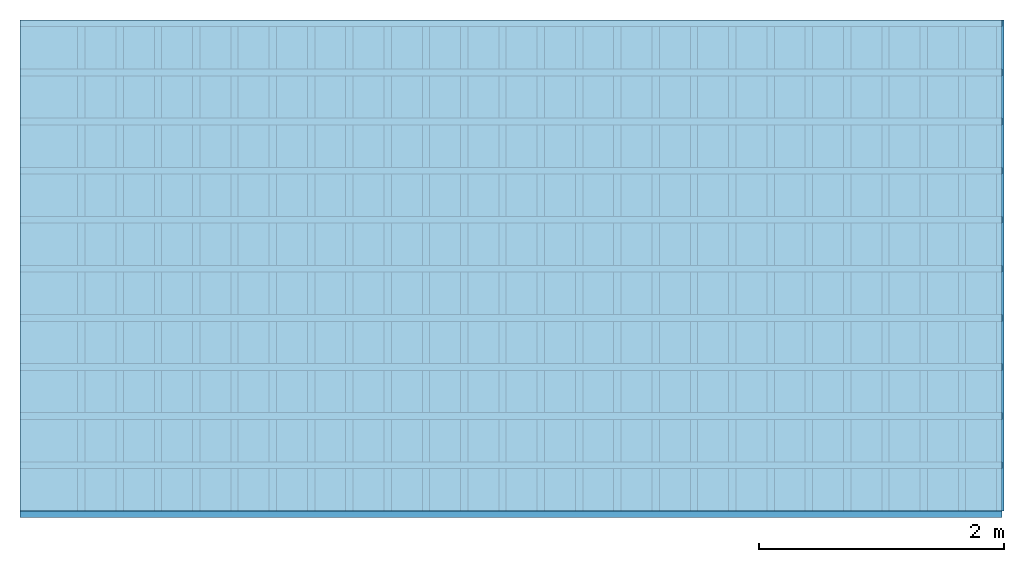
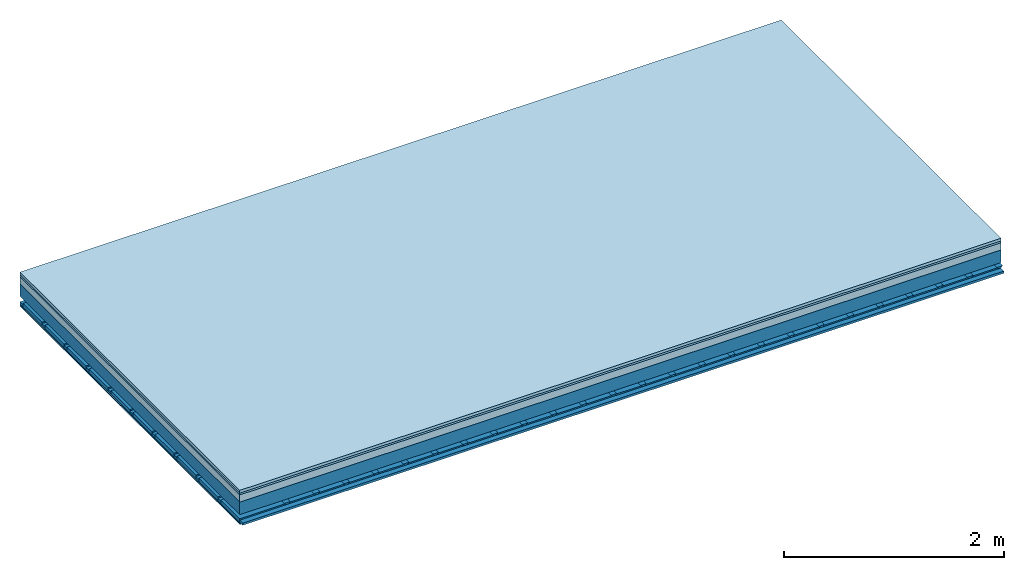
# One storey: 5 plates, 4 members, 1 element without a shape of its own.
"""IFC4 building model written with IfcOpenShell, lengths in metres."""

import ifcopenshell
import ifcopenshell.guid

model = None  # the IFC model being written
_history = None  # IfcOwnerHistory: only IFC2X3 demands one
_inside = {}  # id of a spatial element -> (the spatial element, [elements in it])
_under = {}  # id of a project, library or spatial element -> (it, [spatial elements below it])
_declared = {}  # id of a project -> (the project, [libraries it declares])
_typed = {}  # id of a type object -> (the type object, [elements of that type])
_made_of = {}  # id of a material, layer set ... -> (it, [elements and type objects made of it])


def new_model(schema):
    """Start an empty IFC model of exactly this schema.

    Asked for "IFC4X3", IfcOpenShell would pick the latest addendum, in which some entities
    have other attributes; the version numbers below select the first issue.
    IFC2X3 requires an IfcOwnerHistory on every rooted entity: one is made here for all.
    """
    global model, _history
    if schema == "IFC4X3":
        model = ifcopenshell.file(schema_version=(4, 3, 0, 0))
    else:
        model = ifcopenshell.file(schema=schema)
    _inside.clear()
    _under.clear()
    _declared.clear()
    _typed.clear()
    _made_of.clear()
    _history = None
    if model.schema == "IFC2X3":
        org = make("IfcOrganization", Name="unknown")
        user = make(
            "IfcPersonAndOrganization",
            ThePerson=make("IfcPerson", FamilyName="unknown"),
            TheOrganization=org,
        )
        app = make(
            "IfcApplication",
            ApplicationDeveloper=org,
            Version="unknown",
            ApplicationFullName="unknown",
            ApplicationIdentifier="unknown",
        )
        _history = make(
            "IfcOwnerHistory",
            OwningUser=user,
            OwningApplication=app,
            ChangeAction="ADDED",
            CreationDate=0,
        )
    return model


def make(cls, **values):
    """One entity of the class cls with the attributes given. An attribute that is None is left unset."""
    return model.create_entity(
        cls, **{name: value for name, value in values.items() if value is not None}
    )


def rooted(cls, **values):
    """An entity with a GlobalId (a new one), such as an element, a storey or a relation."""
    return make(cls, GlobalId=ifcopenshell.guid.new(), OwnerHistory=_history, **values)


def si_unit(unit_type, name, prefix=None):
    """IfcSIUnit, for example si_unit("LENGTHUNIT", "METRE", prefix="MILLI")."""
    return make("IfcSIUnit", UnitType=unit_type, Prefix=prefix, Name=name)


def derived_unit(unit_type, elements):
    """IfcDerivedUnit: a product of units, each with its exponent."""
    return make(
        "IfcDerivedUnit",
        Elements=[
            make("IfcDerivedUnitElement", Unit=unit, Exponent=power)
            for unit, power in elements
        ],
        UnitType=unit_type,
    )


def assignment(units):
    """IfcUnitAssignment: the units of a project."""
    return None if units is None else make("IfcUnitAssignment", Units=units)


def point(xyz):
    """IfcCartesianPoint."""
    return None if xyz is None else make("IfcCartesianPoint", Coordinates=xyz)


def direction(xyz):
    """IfcDirection."""
    return None if xyz is None else make("IfcDirection", DirectionRatios=xyz)


def frame(location, z_axis=None, x_axis=None):
    """IfcAxis2Placement3D, a coordinate frame: its origin and axes. An axis left out is left unset."""
    return make(
        "IfcAxis2Placement3D",
        Location=point(location),
        Axis=direction(z_axis),
        RefDirection=direction(x_axis),
    )


def frame_2d(location, x_axis=None):
    """IfcAxis2Placement2D, a coordinate frame in the plane: its origin and x axis."""
    return make(
        "IfcAxis2Placement2D", Location=point(location), RefDirection=direction(x_axis)
    )


def origin():
    """The frame at (0, 0, 0) with its axes left unset."""
    return frame((0.0, 0.0, 0.0))


def origin_with_axes():
    """The frame at (0, 0, 0) with the z axis (0, 0, 1) and the x axis (1, 0, 0) written out."""
    return frame((0.0, 0.0, 0.0), z_axis=(0.0, 0.0, 1.0), x_axis=(1.0, 0.0, 0.0))


def place(relative_to, where):
    """IfcLocalPlacement: puts the frame where relative to a parent placement (None: the world)."""
    return make(
        "IfcLocalPlacement", PlacementRelTo=relative_to, RelativePlacement=where
    )


def context(
    kind, dimensions, precision=None, world=None, true_north=None, identifier=None
):
    """IfcGeometricRepresentationContext, for example the 3D "Model" context."""
    return make(
        "IfcGeometricRepresentationContext",
        ContextIdentifier=identifier,
        ContextType=kind,
        CoordinateSpaceDimension=dimensions,
        Precision=precision,
        WorldCoordinateSystem=world,
        TrueNorth=true_north,
    )


def project(units=None, contexts=None):
    """IfcProject with its units and contexts."""
    return rooted(
        "IfcProject",
        Name="project",
        RepresentationContexts=contexts,
        UnitsInContext=assignment(units),
    )


def spatial(cls, under=None, at=None, **own):
    """A site, building, storey or space (cls), placed at a placement, below another one or the project."""
    s = rooted(cls, ObjectPlacement=at, **own)
    if under is not None:
        _under.setdefault(under.id(), (under, []))[1].append(s)
    return s


def polyline(points):
    """IfcPolyline through the points."""
    return make("IfcPolyline", Points=[point(p) for p in points])


def profile(cls, at=None, kind="AREA", **sizes):
    """A parametric profile (cls). Its sizes go by their IFC names, for example OverallWidth=200.0."""
    return make(cls, ProfileType=kind, Position=at, **sizes)


def rectangle(**sizes):
    """IfcRectangleProfileDef."""
    return profile("IfcRectangleProfileDef", **sizes)


def outline(outer, holes=None, kind="AREA"):
    """IfcArbitraryClosedProfileDef: a profile drawn as a closed curve; with holes, ...WithVoids."""
    if holes is None:
        return make("IfcArbitraryClosedProfileDef", ProfileType=kind, OuterCurve=outer)
    return make(
        "IfcArbitraryProfileDefWithVoids",
        ProfileType=kind,
        OuterCurve=outer,
        InnerCurves=holes,
    )


def extrude(swept, where, along, depth):
    """IfcExtrudedAreaSolid: the profile swept, set in the frame where, extruded along a direction by depth."""
    return make(
        "IfcExtrudedAreaSolid",
        SweptArea=swept,
        Position=where,
        ExtrudedDirection=direction(along),
        Depth=depth,
    )


def shape(context_of_items, identifier, shape_type, items):
    """IfcShapeRepresentation: the items that make up one representation, for example the "Body"."""
    return make(
        "IfcShapeRepresentation",
        ContextOfItems=context_of_items,
        RepresentationIdentifier=identifier,
        RepresentationType=shape_type,
        Items=items,
    )


def material(Name=None, Category=None):
    """IfcMaterial."""
    return make("IfcMaterial", Name=Name, Category=Category)


def layer(
    of_material, thickness, ventilated=None, Name=None, Category=None, Priority=None
):
    """IfcMaterialLayer: one layer of a wall or slab, of a material (None: an air gap)."""
    return make(
        "IfcMaterialLayer",
        Material=of_material,
        LayerThickness=thickness,
        IsVentilated=ventilated,
        Name=Name,
        Category=Category,
        Priority=Priority,
    )


def layer_set(layers, Name=None):
    """IfcMaterialLayerSet."""
    return make("IfcMaterialLayerSet", MaterialLayers=layers, LayerSetName=Name)


def made_of(thing, what):
    """Note that an element or type object is made of a material, layer set ...; save() writes the relation."""
    if what is not None:
        _made_of.setdefault(what.id(), (what, []))[1].append(thing)
    return thing


def type_object(cls, material=None, **own):
    """A type object (cls), such as IfcWallType, which elements share."""
    return made_of(rooted(cls, **own), material)


def element(
    cls,
    number,
    at=None,
    inside=None,
    cuts=None,
    type_object=None,
    material=None,
    context=None,
    identifier="Body",
    shape_type=None,
    held_by="IfcProductDefinitionShape",
    body=None,
    shapes=None,
    **own,
):
    """One element of the class cls, such as IfcWall. Its Tag is "e" and its number.

    at: its placement. inside: the storey or other place that contains it. cuts: it is an
    opening in that element (IfcRelVoidsElement). A single representation is given by context,
    identifier, shape_type and body (its items); several are given by shapes. held_by: the class
    of the entity that holds the representations. save() writes the other relations.
    """
    e = rooted(cls, Tag="e%d" % number, ObjectPlacement=at, **own)
    if body is not None:
        shapes = [shape(context, identifier, shape_type, body)]
    if shapes is not None:
        e.Representation = make(held_by, Representations=shapes)
    if inside is not None:
        _inside.setdefault(inside.id(), (inside, []))[1].append(e)
    if cuts is not None:
        rooted(
            "IfcRelVoidsElement", RelatingBuildingElement=cuts, RelatedOpeningElement=e
        )
    if type_object is not None:
        _typed.setdefault(type_object.id(), (type_object, []))[1].append(e)
    return made_of(e, material)


def aggregate(whole, parts):
    """IfcRelAggregates: a whole, such as a stair, and the parts it consists of."""
    return rooted("IfcRelAggregates", RelatingObject=whole, RelatedObjects=parts)


def save(model, path):
    """Write the relations noted so far, then the file.

    IfcRelAggregates (storeys below a building ...), IfcRelContainedInSpatialStructure (elements
    in a storey), IfcRelDefinesByType, IfcRelAssociatesMaterial and IfcRelDeclares: one each for
    every whole, place, type object, material and project.
    """
    for whole, parts in _under.values():
        aggregate(whole, parts)
    for where, things in _inside.values():
        rooted(
            "IfcRelContainedInSpatialStructure",
            RelatedElements=things,
            RelatingStructure=where,
        )
    for kind, things in _typed.values():
        rooted("IfcRelDefinesByType", RelatedObjects=things, RelatingType=kind)
    for what, things in _made_of.values():
        rooted("IfcRelAssociatesMaterial", RelatedObjects=things, RelatingMaterial=what)
    for by, libraries in _declared.values():
        rooted("IfcRelDeclares", RelatingContext=by, RelatedDefinitions=libraries)
    model.write(path)


model = new_model("IFC4")

# Units and contexts
plan_context = context("Plan", 3, precision=1e-05, world=origin(), true_north=direction((0.0, 1.0)))
model_context = context("Model", 3, precision=1e-05, world=origin(), true_north=direction((0.0, 1.0)))
ifc_project = project(units=[si_unit("LENGTHUNIT", "METRE"), derived_unit("SOUNDPRESSUREUNIT", [(si_unit("PRESSUREUNIT", "PASCAL", prefix="MICRO"), 0)]), si_unit("ENERGYUNIT", "JOULE", prefix="MEGA"), si_unit("MASSUNIT", "GRAM", prefix="KILO"), derived_unit("THERMALTRANSMITTANCEUNIT", [(si_unit("POWERUNIT", "WATT"), 1), (si_unit("AREAUNIT", "SQUARE_METRE"), -1), (si_unit("THERMODYNAMICTEMPERATUREUNIT", "KELVIN"), -1)]), derived_unit("AREADENSITYUNIT", [(si_unit("MASSUNIT", "GRAM", prefix="KILO"), 1), (si_unit("AREAUNIT", "SQUARE_METRE"), -1)]), derived_unit("USERDEFINED", [(si_unit("ENERGYUNIT", "JOULE", prefix="MEGA"), 1), (si_unit("AREAUNIT", "SQUARE_METRE"), -1)])], contexts=[plan_context, model_context])

# Site, building, storey
site = spatial("IfcSite", under=ifc_project)
building_placement = place(None, origin())
building = spatial("IfcBuilding", under=site, at=building_placement)
storey_placement = place(building_placement, origin())
storey = spatial("IfcBuildingStorey", under=building, at=storey_placement)

# Slab, members, plates
ifc_material_1 = material(Name="Phone Star TRI", Category="03.013")
ifc_layer_1 = layer(ifc_material_1, 0.03, Name="On-material")
ifc_material_2 = material(Name="EP3")
ifc_layer_2 = layer(ifc_material_2, 0.02, Name="Impact sound insulation")
ifc_material_3 = material(Category="03.011")
ifc_layer_3 = layer(ifc_material_3, 0.08, Name="on Supporting structure")
ifc_material_4 = material(Name="no composite action")
ifc_layer_4 = layer(ifc_material_4, 0.0, Name="Bond")
ifc_layer_5 = layer(None, 0.14, Name="Supporting structure")
ifc_material_5 = material(Name="of the art")
ifc_layer_6 = layer(ifc_material_5, 0.0, Name="Bond")
ifc_layer_7 = layer(None, 0.06, Name="Coupling")
ifc_layer_8 = layer(None, 0.025, Name="Battens / profiles")
ifc_layer_9 = layer(ifc_material_1, 0.0125, Name="Ceiling covering 1st layer")
ifc_material_6 = material(Name="Plasterboard type A", Category="03.008")
ifc_layer_10 = layer(ifc_material_6, 0.0125, Name="Ceiling covering layer 2")
ifc_material_7 = material(Name="joints", Category="04.017")
ifc_layer_11 = layer(ifc_material_7, 0.0, Name="Surface / treatment")
ifc_layer_set = layer_set([ifc_layer_1, ifc_layer_2, ifc_layer_3, ifc_layer_4, ifc_layer_5, ifc_layer_6, ifc_layer_7, ifc_layer_8, ifc_layer_9, ifc_layer_10, ifc_layer_11])
slab_type = type_object("IfcSlabType", Name="A2426", PredefinedType="NOTDEFINED", material=ifc_layer_set)
slab_placement = place(None, frame((0.0, 0.0, 0.0), z_axis=(0.0, 0.0, -1.0), x_axis=(1.0, 0.0, 0.0)))
slab = element("IfcSlab", 1, at=slab_placement, inside=storey, type_object=slab_type, material=ifc_layer_set, Name="Slab #1")
ifc_material_8 = material()
member_1_placement = place(slab_placement, origin())
member_1 = element("IfcMember", 2, at=member_1_placement, material=ifc_material_8, Name="Supporting structure", context=plan_context, shape_type="SweptSolid", body=[
    extrude(rectangle(XDim=1.0, YDim=0.14, at=frame_2d((0.5, 0.07), x_axis=(1.0, 0.0))), frame((0.0, 4.0, 0.13), z_axis=(0.0, -1.0, 0.0), x_axis=(1.0, 0.0, 0.0)), (0.0, 0.0, 1.0), 4.0),
    extrude(rectangle(XDim=1.0, YDim=0.14, at=frame_2d((0.5, 0.07), x_axis=(1.0, 0.0))), frame((1.0, 4.0, 0.13), z_axis=(0.0, -1.0, 0.0), x_axis=(1.0, 0.0, 0.0)), (0.0, 0.0, 1.0), 4.0),
    extrude(rectangle(XDim=1.0, YDim=0.14, at=frame_2d((0.5, 0.07), x_axis=(1.0, 0.0))), frame((2.0, 4.0, 0.13), z_axis=(0.0, -1.0, 0.0), x_axis=(1.0, 0.0, 0.0)), (0.0, 0.0, 1.0), 4.0),
    extrude(rectangle(XDim=1.0, YDim=0.14, at=frame_2d((0.5, 0.07), x_axis=(1.0, 0.0))), frame((3.0, 4.0, 0.13), z_axis=(0.0, -1.0, 0.0), x_axis=(1.0, 0.0, 0.0)), (0.0, 0.0, 1.0), 4.0),
    extrude(rectangle(XDim=1.0, YDim=0.14, at=frame_2d((0.5, 0.07), x_axis=(1.0, 0.0))), frame((4.0, 4.0, 0.13), z_axis=(0.0, -1.0, 0.0), x_axis=(1.0, 0.0, 0.0)), (0.0, 0.0, 1.0), 4.0),
    extrude(rectangle(XDim=1.0, YDim=0.14, at=frame_2d((0.5, 0.07), x_axis=(1.0, 0.0))), frame((5.0, 4.0, 0.13), z_axis=(0.0, -1.0, 0.0), x_axis=(1.0, 0.0, 0.0)), (0.0, 0.0, 1.0), 4.0),
    extrude(rectangle(XDim=1.0, YDim=0.14, at=frame_2d((0.5, 0.07), x_axis=(1.0, 0.0))), frame((6.0, 4.0, 0.13), z_axis=(0.0, -1.0, 0.0), x_axis=(1.0, 0.0, 0.0)), (0.0, 0.0, 1.0), 4.0),
    extrude(rectangle(XDim=1.0, YDim=0.14, at=frame_2d((0.5, 0.07), x_axis=(1.0, 0.0))), frame((7.0, 4.0, 0.13), z_axis=(0.0, -1.0, 0.0), x_axis=(1.0, 0.0, 0.0)), (0.0, 0.0, 1.0), 4.0),
])
ifc_material_9 = material()
member_2_placement = place(slab_placement, origin())
member_2 = element("IfcMember", 3, at=member_2_placement, material=ifc_material_9, Name="Coupling", context=plan_context, shape_type="SweptSolid", body=[
    extrude(outline(polyline([(0.0, 0.0), (0.06, 0.0), (0.04, 0.02), (0.02, 0.02), (0.0, 0.0)])), frame((0.47, 4.0, 0.31), z_axis=(0.0, -1.0, 0.0), x_axis=(1.0, 0.0, 0.0)), (0.0, 0.0, 1.0), 4.0),
    extrude(outline(polyline([(0.0, 0.0), (0.06, 0.0), (0.04, 0.02), (0.02, 0.02), (0.0, 0.0)])), frame((0.782, 4.0, 0.31), z_axis=(0.0, -1.0, 0.0), x_axis=(1.0, 0.0, 0.0)), (0.0, 0.0, 1.0), 4.0),
    extrude(outline(polyline([(0.0, 0.0), (0.06, 0.0), (0.04, 0.02), (0.02, 0.02), (0.0, 0.0)])), frame((1.094, 4.0, 0.31), z_axis=(0.0, -1.0, 0.0), x_axis=(1.0, 0.0, 0.0)), (0.0, 0.0, 1.0), 4.0),
    extrude(outline(polyline([(0.0, 0.0), (0.06, 0.0), (0.04, 0.02), (0.02, 0.02), (0.0, 0.0)])), frame((1.406, 4.0, 0.31), z_axis=(0.0, -1.0, 0.0), x_axis=(1.0, 0.0, 0.0)), (0.0, 0.0, 1.0), 4.0),
    extrude(outline(polyline([(0.0, 0.0), (0.06, 0.0), (0.04, 0.02), (0.02, 0.02), (0.0, 0.0)])), frame((1.718, 4.0, 0.31), z_axis=(0.0, -1.0, 0.0), x_axis=(1.0, 0.0, 0.0)), (0.0, 0.0, 1.0), 4.0),
    extrude(outline(polyline([(0.0, 0.0), (0.06, 0.0), (0.04, 0.02), (0.02, 0.02), (0.0, 0.0)])), frame((2.03, 4.0, 0.31), z_axis=(0.0, -1.0, 0.0), x_axis=(1.0, 0.0, 0.0)), (0.0, 0.0, 1.0), 4.0),
    extrude(outline(polyline([(0.0, 0.0), (0.06, 0.0), (0.04, 0.02), (0.02, 0.02), (0.0, 0.0)])), frame((2.342, 4.0, 0.31), z_axis=(0.0, -1.0, 0.0), x_axis=(1.0, 0.0, 0.0)), (0.0, 0.0, 1.0), 4.0),
    extrude(outline(polyline([(0.0, 0.0), (0.06, 0.0), (0.04, 0.02), (0.02, 0.02), (0.0, 0.0)])), frame((2.654, 4.0, 0.31), z_axis=(0.0, -1.0, 0.0), x_axis=(1.0, 0.0, 0.0)), (0.0, 0.0, 1.0), 4.0),
    extrude(outline(polyline([(0.0, 0.0), (0.06, 0.0), (0.04, 0.02), (0.02, 0.02), (0.0, 0.0)])), frame((2.966, 4.0, 0.31), z_axis=(0.0, -1.0, 0.0), x_axis=(1.0, 0.0, 0.0)), (0.0, 0.0, 1.0), 4.0),
    extrude(outline(polyline([(0.0, 0.0), (0.06, 0.0), (0.04, 0.02), (0.02, 0.02), (0.0, 0.0)])), frame((3.278, 4.0, 0.31), z_axis=(0.0, -1.0, 0.0), x_axis=(1.0, 0.0, 0.0)), (0.0, 0.0, 1.0), 4.0),
    extrude(outline(polyline([(0.0, 0.0), (0.06, 0.0), (0.04, 0.02), (0.02, 0.02), (0.0, 0.0)])), frame((3.59, 4.0, 0.31), z_axis=(0.0, -1.0, 0.0), x_axis=(1.0, 0.0, 0.0)), (0.0, 0.0, 1.0), 4.0),
    extrude(outline(polyline([(0.0, 0.0), (0.06, 0.0), (0.04, 0.02), (0.02, 0.02), (0.0, 0.0)])), frame((3.902, 4.0, 0.31), z_axis=(0.0, -1.0, 0.0), x_axis=(1.0, 0.0, 0.0)), (0.0, 0.0, 1.0), 4.0),
    extrude(outline(polyline([(0.0, 0.0), (0.06, 0.0), (0.04, 0.02), (0.02, 0.02), (0.0, 0.0)])), frame((4.214, 4.0, 0.31), z_axis=(0.0, -1.0, 0.0), x_axis=(1.0, 0.0, 0.0)), (0.0, 0.0, 1.0), 4.0),
    extrude(outline(polyline([(0.0, 0.0), (0.06, 0.0), (0.04, 0.02), (0.02, 0.02), (0.0, 0.0)])), frame((4.526, 4.0, 0.31), z_axis=(0.0, -1.0, 0.0), x_axis=(1.0, 0.0, 0.0)), (0.0, 0.0, 1.0), 4.0),
    extrude(outline(polyline([(0.0, 0.0), (0.06, 0.0), (0.04, 0.02), (0.02, 0.02), (0.0, 0.0)])), frame((4.838, 4.0, 0.31), z_axis=(0.0, -1.0, 0.0), x_axis=(1.0, 0.0, 0.0)), (0.0, 0.0, 1.0), 4.0),
    extrude(outline(polyline([(0.0, 0.0), (0.06, 0.0), (0.04, 0.02), (0.02, 0.02), (0.0, 0.0)])), frame((5.15, 4.0, 0.31), z_axis=(0.0, -1.0, 0.0), x_axis=(1.0, 0.0, 0.0)), (0.0, 0.0, 1.0), 4.0),
    extrude(outline(polyline([(0.0, 0.0), (0.06, 0.0), (0.04, 0.02), (0.02, 0.02), (0.0, 0.0)])), frame((5.462, 4.0, 0.31), z_axis=(0.0, -1.0, 0.0), x_axis=(1.0, 0.0, 0.0)), (0.0, 0.0, 1.0), 4.0),
    extrude(outline(polyline([(0.0, 0.0), (0.06, 0.0), (0.04, 0.02), (0.02, 0.02), (0.0, 0.0)])), frame((5.774, 4.0, 0.31), z_axis=(0.0, -1.0, 0.0), x_axis=(1.0, 0.0, 0.0)), (0.0, 0.0, 1.0), 4.0),
    extrude(outline(polyline([(0.0, 0.0), (0.06, 0.0), (0.04, 0.02), (0.02, 0.02), (0.0, 0.0)])), frame((6.086, 4.0, 0.31), z_axis=(0.0, -1.0, 0.0), x_axis=(1.0, 0.0, 0.0)), (0.0, 0.0, 1.0), 4.0),
    extrude(outline(polyline([(0.0, 0.0), (0.06, 0.0), (0.04, 0.02), (0.02, 0.02), (0.0, 0.0)])), frame((6.398, 4.0, 0.31), z_axis=(0.0, -1.0, 0.0), x_axis=(1.0, 0.0, 0.0)), (0.0, 0.0, 1.0), 4.0),
    extrude(outline(polyline([(0.0, 0.0), (0.06, 0.0), (0.04, 0.02), (0.02, 0.02), (0.0, 0.0)])), frame((6.71, 4.0, 0.31), z_axis=(0.0, -1.0, 0.0), x_axis=(1.0, 0.0, 0.0)), (0.0, 0.0, 1.0), 4.0),
    extrude(outline(polyline([(0.0, 0.0), (0.06, 0.0), (0.04, 0.02), (0.02, 0.02), (0.0, 0.0)])), frame((7.022, 4.0, 0.31), z_axis=(0.0, -1.0, 0.0), x_axis=(1.0, 0.0, 0.0)), (0.0, 0.0, 1.0), 4.0),
    extrude(outline(polyline([(0.0, 0.0), (0.06, 0.0), (0.04, 0.02), (0.02, 0.02), (0.0, 0.0)])), frame((7.334, 4.0, 0.31), z_axis=(0.0, -1.0, 0.0), x_axis=(1.0, 0.0, 0.0)), (0.0, 0.0, 1.0), 4.0),
    extrude(outline(polyline([(0.0, 0.0), (0.06, 0.0), (0.04, 0.02), (0.02, 0.02), (0.0, 0.0)])), frame((7.646, 4.0, 0.31), z_axis=(0.0, -1.0, 0.0), x_axis=(1.0, 0.0, 0.0)), (0.0, 0.0, 1.0), 4.0),
    extrude(outline(polyline([(0.0, 0.0), (0.06, 0.0), (0.04, 0.02), (0.02, 0.02), (0.0, 0.0)])), frame((7.958, 4.0, 0.31), z_axis=(0.0, -1.0, 0.0), x_axis=(1.0, 0.0, 0.0)), (0.0, 0.0, 1.0), 4.0),
])
ifc_material_10 = material()
member_3_placement = place(slab_placement, origin())
member_3 = element("IfcMember", 4, at=member_3_placement, material=ifc_material_10, Name="Battens / profiles", context=plan_context, shape_type="SweptSolid", body=[
    extrude(rectangle(XDim=0.055, YDim=0.025, at=frame_2d((0.0275, 0.0125), x_axis=(1.0, 0.0))), frame((0.0, 0.0, 0.33), z_axis=(1.0, 0.0, 0.0), x_axis=(0.0, 1.0, 0.0)), (0.0, 0.0, 1.0), 8.0),
    extrude(rectangle(XDim=0.055, YDim=0.025, at=frame_2d((0.0275, 0.0125), x_axis=(1.0, 0.0))), frame((0.0, 0.4, 0.33), z_axis=(1.0, 0.0, 0.0), x_axis=(0.0, 1.0, 0.0)), (0.0, 0.0, 1.0), 8.0),
    extrude(rectangle(XDim=0.055, YDim=0.025, at=frame_2d((0.0275, 0.0125), x_axis=(1.0, 0.0))), frame((0.0, 0.8, 0.33), z_axis=(1.0, 0.0, 0.0), x_axis=(0.0, 1.0, 0.0)), (0.0, 0.0, 1.0), 8.0),
    extrude(rectangle(XDim=0.055, YDim=0.025, at=frame_2d((0.0275, 0.0125), x_axis=(1.0, 0.0))), frame((0.0, 1.2, 0.33), z_axis=(1.0, 0.0, 0.0), x_axis=(0.0, 1.0, 0.0)), (0.0, 0.0, 1.0), 8.0),
    extrude(rectangle(XDim=0.055, YDim=0.025, at=frame_2d((0.0275, 0.0125), x_axis=(1.0, 0.0))), frame((0.0, 1.6, 0.33), z_axis=(1.0, 0.0, 0.0), x_axis=(0.0, 1.0, 0.0)), (0.0, 0.0, 1.0), 8.0),
    extrude(rectangle(XDim=0.055, YDim=0.025, at=frame_2d((0.0275, 0.0125), x_axis=(1.0, 0.0))), frame((0.0, 2.0, 0.33), z_axis=(1.0, 0.0, 0.0), x_axis=(0.0, 1.0, 0.0)), (0.0, 0.0, 1.0), 8.0),
    extrude(rectangle(XDim=0.055, YDim=0.025, at=frame_2d((0.0275, 0.0125), x_axis=(1.0, 0.0))), frame((0.0, 2.4, 0.33), z_axis=(1.0, 0.0, 0.0), x_axis=(0.0, 1.0, 0.0)), (0.0, 0.0, 1.0), 8.0),
    extrude(rectangle(XDim=0.055, YDim=0.025, at=frame_2d((0.0275, 0.0125), x_axis=(1.0, 0.0))), frame((0.0, 2.8, 0.33), z_axis=(1.0, 0.0, 0.0), x_axis=(0.0, 1.0, 0.0)), (0.0, 0.0, 1.0), 8.0),
    extrude(rectangle(XDim=0.055, YDim=0.025, at=frame_2d((0.0275, 0.0125), x_axis=(1.0, 0.0))), frame((0.0, 3.2, 0.33), z_axis=(1.0, 0.0, 0.0), x_axis=(0.0, 1.0, 0.0)), (0.0, 0.0, 1.0), 8.0),
    extrude(rectangle(XDim=0.055, YDim=0.025, at=frame_2d((0.0275, 0.0125), x_axis=(1.0, 0.0))), frame((0.0, 3.6, 0.33), z_axis=(1.0, 0.0, 0.0), x_axis=(0.0, 1.0, 0.0)), (0.0, 0.0, 1.0), 8.0),
    extrude(rectangle(XDim=0.055, YDim=0.025, at=frame_2d((0.0275, 0.0125), x_axis=(1.0, 0.0))), frame((0.0, 4.0, 0.33), z_axis=(1.0, 0.0, 0.0), x_axis=(0.0, 1.0, 0.0)), (0.0, 0.0, 1.0), 8.0),
])
ifc_material_11 = material()
member_4_placement = place(slab_placement, origin())
member_4 = element("IfcMember", 5, at=member_4_placement, material=ifc_material_11, Name="Cavity", context=plan_context, shape_type="SweptSolid", body=[
    extrude(rectangle(XDim=0.345, YDim=0.04, at=frame_2d((0.1725, 0.02), x_axis=(1.0, 0.0))), frame((0.0, 0.055, 0.315), z_axis=(1.0, 0.0, 0.0), x_axis=(0.0, 1.0, 0.0)), (0.0, 0.0, 1.0), 8.0),
    extrude(rectangle(XDim=0.345, YDim=0.04, at=frame_2d((0.1725, 0.02), x_axis=(1.0, 0.0))), frame((0.0, 0.455, 0.315), z_axis=(1.0, 0.0, 0.0), x_axis=(0.0, 1.0, 0.0)), (0.0, 0.0, 1.0), 8.0),
    extrude(rectangle(XDim=0.345, YDim=0.04, at=frame_2d((0.1725, 0.02), x_axis=(1.0, 0.0))), frame((0.0, 0.855, 0.315), z_axis=(1.0, 0.0, 0.0), x_axis=(0.0, 1.0, 0.0)), (0.0, 0.0, 1.0), 8.0),
    extrude(rectangle(XDim=0.345, YDim=0.04, at=frame_2d((0.1725, 0.02), x_axis=(1.0, 0.0))), frame((0.0, 1.255, 0.315), z_axis=(1.0, 0.0, 0.0), x_axis=(0.0, 1.0, 0.0)), (0.0, 0.0, 1.0), 8.0),
    extrude(rectangle(XDim=0.345, YDim=0.04, at=frame_2d((0.1725, 0.02), x_axis=(1.0, 0.0))), frame((0.0, 1.655, 0.315), z_axis=(1.0, 0.0, 0.0), x_axis=(0.0, 1.0, 0.0)), (0.0, 0.0, 1.0), 8.0),
    extrude(rectangle(XDim=0.345, YDim=0.04, at=frame_2d((0.1725, 0.02), x_axis=(1.0, 0.0))), frame((0.0, 2.055, 0.315), z_axis=(1.0, 0.0, 0.0), x_axis=(0.0, 1.0, 0.0)), (0.0, 0.0, 1.0), 8.0),
    extrude(rectangle(XDim=0.345, YDim=0.04, at=frame_2d((0.1725, 0.02), x_axis=(1.0, 0.0))), frame((0.0, 2.455, 0.315), z_axis=(1.0, 0.0, 0.0), x_axis=(0.0, 1.0, 0.0)), (0.0, 0.0, 1.0), 8.0),
    extrude(rectangle(XDim=0.345, YDim=0.04, at=frame_2d((0.1725, 0.02), x_axis=(1.0, 0.0))), frame((0.0, 2.855, 0.315), z_axis=(1.0, 0.0, 0.0), x_axis=(0.0, 1.0, 0.0)), (0.0, 0.0, 1.0), 8.0),
    extrude(rectangle(XDim=0.345, YDim=0.04, at=frame_2d((0.1725, 0.02), x_axis=(1.0, 0.0))), frame((0.0, 3.255, 0.315), z_axis=(1.0, 0.0, 0.0), x_axis=(0.0, 1.0, 0.0)), (0.0, 0.0, 1.0), 8.0),
    extrude(rectangle(XDim=0.345, YDim=0.04, at=frame_2d((0.1725, 0.02), x_axis=(1.0, 0.0))), frame((0.0, 3.655, 0.315), z_axis=(1.0, 0.0, 0.0), x_axis=(0.0, 1.0, 0.0)), (0.0, 0.0, 1.0), 8.0),
])
plate_1_placement = place(slab_placement, origin())
plate_1 = element("IfcPlate", 6, at=plate_1_placement, material=ifc_material_1, Name="On-material", context=plan_context, shape_type="SweptSolid", body=[
    extrude(rectangle(XDim=8.0, YDim=4.0, at=frame_2d((4.0, 2.0), x_axis=(1.0, 0.0))), origin_with_axes(), (0.0, 0.0, 1.0), 0.03),
])
plate_2_placement = place(slab_placement, origin())
plate_2 = element("IfcPlate", 7, at=plate_2_placement, material=ifc_material_2, Name="Impact sound insulation", context=plan_context, shape_type="SweptSolid", body=[
    extrude(rectangle(XDim=8.0, YDim=4.0, at=frame_2d((4.0, 2.0), x_axis=(1.0, 0.0))), frame((0.0, 0.0, 0.03), z_axis=(0.0, 0.0, 1.0), x_axis=(1.0, 0.0, 0.0)), (0.0, 0.0, 1.0), 0.02),
])
plate_3_placement = place(slab_placement, origin())
plate_3 = element("IfcPlate", 8, at=plate_3_placement, material=ifc_material_3, Name="on Supporting structure", context=plan_context, shape_type="SweptSolid", body=[
    extrude(rectangle(XDim=8.0, YDim=4.0, at=frame_2d((4.0, 2.0), x_axis=(1.0, 0.0))), frame((0.0, 0.0, 0.05), z_axis=(0.0, 0.0, 1.0), x_axis=(1.0, 0.0, 0.0)), (0.0, 0.0, 1.0), 0.08),
])
plate_4_placement = place(slab_placement, origin())
plate_4 = element("IfcPlate", 9, at=plate_4_placement, material=ifc_material_1, Name="Ceiling covering 1st layer", context=plan_context, shape_type="SweptSolid", body=[
    extrude(rectangle(XDim=8.0, YDim=4.0, at=frame_2d((4.0, 2.0), x_axis=(1.0, 0.0))), frame((0.0, 0.0, 0.355), z_axis=(0.0, 0.0, 1.0), x_axis=(1.0, 0.0, 0.0)), (0.0, 0.0, 1.0), 0.0125),
])
plate_5_placement = place(slab_placement, origin())
plate_5 = element("IfcPlate", 10, at=plate_5_placement, material=ifc_material_6, Name="Ceiling covering layer 2", context=plan_context, shape_type="SweptSolid", body=[
    extrude(rectangle(XDim=8.0, YDim=4.0, at=frame_2d((4.0, 2.0), x_axis=(1.0, 0.0))), frame((0.0, 0.0, 0.3675), z_axis=(0.0, 0.0, 1.0), x_axis=(1.0, 0.0, 0.0)), (0.0, 0.0, 1.0), 0.0125),
])
aggregate(slab, [plate_1, plate_2, plate_3, member_1, member_2, member_3, member_4, plate_4, plate_5])

save(model, "model.ifc")
